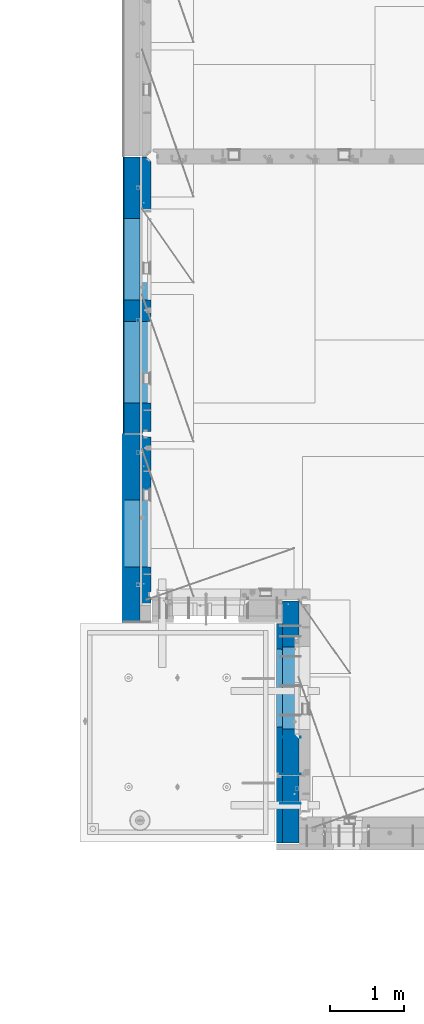
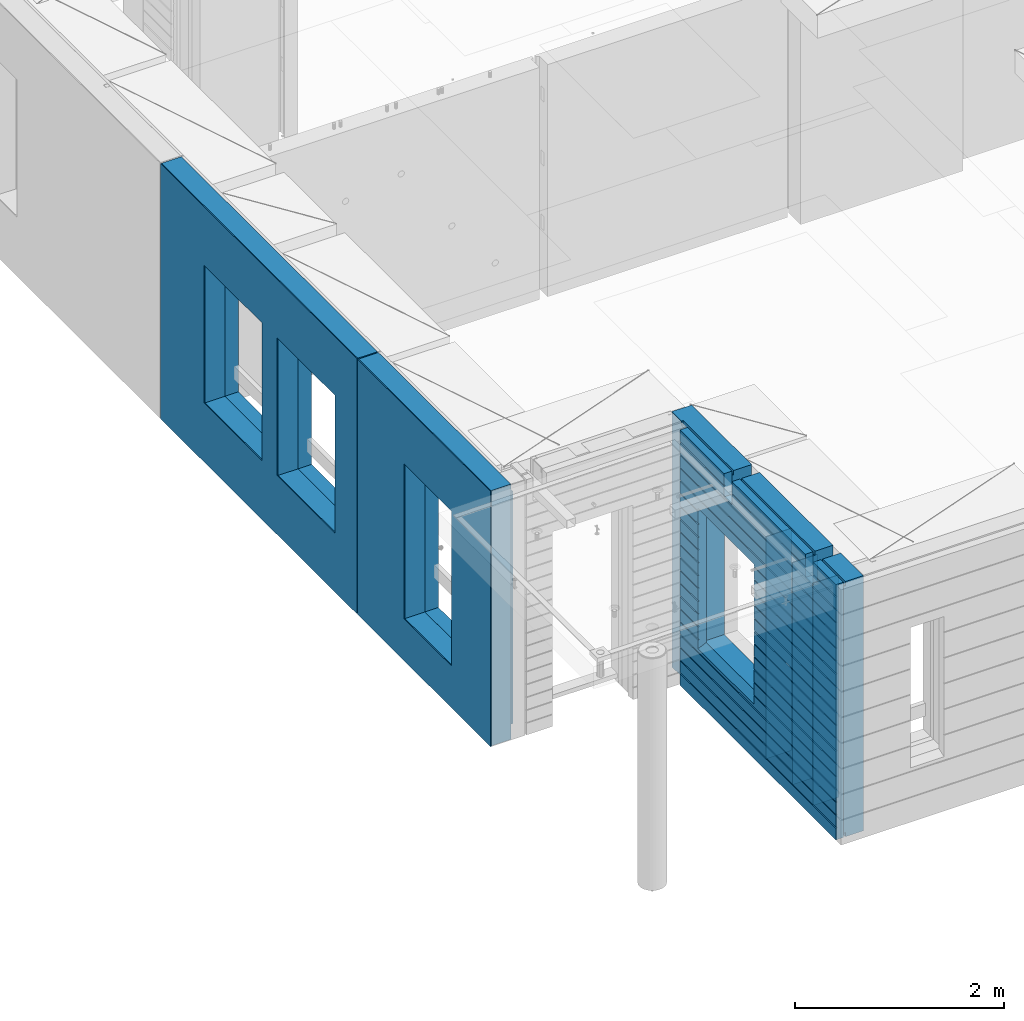
# One storey, part 228 of 352: 11 walls, 3 elements without a shape of their own.
"""IFC2X3 building model written with IfcOpenShell, lengths in millimetres."""

from ifc_helpers import new_model, si_unit, frame, origin_with_axes, place, context, subcontext, project, spatial, faceted_brep, material, type_object, element, aggregate, save


model = new_model("IFC2X3")

# Units and contexts
model_context = context("Model", 3, precision=1e-05, world=origin_with_axes())
body_context = subcontext(model_context, "Body", "Model", "MODEL_VIEW")
ifc_project = project(units=[si_unit("LENGTHUNIT", "METRE", prefix="MILLI"), si_unit("AREAUNIT", "SQUARE_METRE"), si_unit("VOLUMEUNIT", "CUBIC_METRE"), si_unit("MASSUNIT", "GRAM", prefix="KILO"), si_unit("TIMEUNIT", "SECOND"), si_unit("PLANEANGLEUNIT", "RADIAN"), si_unit("SOLIDANGLEUNIT", "STERADIAN"), si_unit("THERMODYNAMICTEMPERATUREUNIT", "DEGREE_CELSIUS"), si_unit("LUMINOUSINTENSITYUNIT", "LUMEN")], contexts=[model_context])

# Site, building, storey
site_placement = place(None, origin_with_axes())
site = spatial("IfcSite", under=ifc_project, at=site_placement, CompositionType="ELEMENT")
building_placement = place(site_placement, origin_with_axes())
building = spatial("IfcBuilding", under=site, at=building_placement, CompositionType="ELEMENT")
storey_placement = place(building_placement, origin_with_axes())
storey = spatial("IfcBuildingStorey", under=building, at=storey_placement, Name="6", CompositionType="ELEMENT", Elevation=0.0)

# Assembly, walls
assembly_1_placement = place(storey_placement, origin_with_axes())
assembly_1 = element("IfcElementAssembly", 1, at=assembly_1_placement, inside=storey, AssemblyPlace="NOTDEFINED", PredefinedType="REINFORCEMENT_UNIT")
ifc_material_1 = material(Name="Undefined")
wall_type_1 = type_object("IfcWallType", PredefinedType="NOTDEFINED")
wall_1_placement = place(assembly_1_placement, frame((10040.0, 8580.0, 98115.0), z_axis=(0.0, 0.0, 1.0), x_axis=(-1.0, 3.00000001838171e-08, 0.0)))
wall_1 = element("IfcWall", 2, at=wall_1_placement, type_object=wall_type_1, material=ifc_material_1, Name="(PD)", context=body_context, shape_type="Brep", body=[
    faceted_brep([(0.0, 5.0, -1300.0), (0.0, 5.0, 1300.0), (280.0, 5.0, 1300.0), (280.0, 5.0, -1300.0), (0.0, -5.0, 1300.0), (280.0, -5.0, 1300.0), (0.0, -5.0, -1300.0), (280.0, -5.0, -1300.0)], [[[0, 1, 2, 3]], [[1, 4, 5, 2]], [[4, 6, 7, 5]], [[6, 0, 3, 7]], [[5, 7, 3, 2]], [[6, 4, 1, 0]]]),
])
wall_2_placement = place(assembly_1_placement, frame((10040.0, 8180.0, 98115.0), z_axis=(0.0, 0.0, 1.0), x_axis=(-1.0, 3.00000001838171e-08, 0.0)))
wall_2 = element("IfcWall", 3, at=wall_2_placement, type_object=wall_type_1, material=ifc_material_1, Name="(PD)", context=body_context, shape_type="Brep", body=[
    faceted_brep([(0.0, 5.0, -1300.0), (0.0, 5.0, 1300.0), (280.0, 5.0, 1300.0), (280.0, 5.0, -1300.0), (0.0, -5.0, 1300.0), (280.0, -5.0, 1300.0), (0.0, -5.0, -1300.0), (280.0, -5.0, -1300.0)], [[[0, 1, 2, 3]], [[1, 4, 5, 2]], [[4, 6, 7, 5]], [[6, 0, 3, 7]], [[5, 7, 3, 2]], [[6, 4, 1, 0]]]),
])
wall_3_placement = place(assembly_1_placement, frame((10040.0, 9080.0, 98115.0), z_axis=(0.0, 0.0, 1.0), x_axis=(-1.0, 3.00000001838171e-08, 0.0)))
wall_3 = element("IfcWall", 4, at=wall_3_placement, type_object=wall_type_1, material=ifc_material_1, Name="(PD)", context=body_context, shape_type="Brep", body=[
    faceted_brep([(0.0, 5.0, -1300.0), (0.0, 5.0, 1300.0), (280.0, 5.0, 1300.0), (280.0, 5.0, -1300.0), (0.0, -5.0, 1300.0), (280.0, -5.0, 1300.0), (0.0, -5.0, -1300.0), (280.0, -5.0, -1300.0)], [[[0, 1, 2, 3]], [[1, 4, 5, 2]], [[4, 6, 7, 5]], [[6, 0, 3, 7]], [[5, 7, 3, 2]], [[6, 4, 1, 0]]]),
])
ifc_material_2 = material(Name="COS5gt")
wall_type_2 = type_object("IfcWallType", PredefinedType="NOTDEFINED")
wall_4_placement = place(assembly_1_placement, frame((9900.0, 8000.0, 98247.5), z_axis=(0.0, 0.0, 1.0), x_axis=(0.0, 1.0, 0.0)))
wall_4 = element("IfcWall", 5, at=wall_4_placement, type_object=wall_type_2, material=ifc_material_2, context=body_context, shape_type="Brep", body=[
    faceted_brep([(-355.0, 110.0, -1442.5), (2751.0, 110.0, -1442.5), (2751.0, 90.0, -1442.5), (-355.0, 90.0, -1442.5), (2935.0, 110.0, -1492.5), (2935.0, -110.0, -1492.5), (-355.0, -110.0, -1492.5), (-355.0, 90.0, -1492.5), (2751.0, 90.0, -1492.5), (2751.0, 110.0, -1492.5), (2935.0, -110.0, 1492.5), (2935.0, 110.0, 1492.5), (2751.0, 110.0, 1492.5), (2751.0, 90.0, 1492.5), (1785.0, 90.0, 1492.5), (1785.0, -110.0, 1492.5), (2751.0, 90.0, 1442.5), (1785.0, 90.0, 1442.5), (2751.0, 110.0, 1442.5), (1785.0, 110.0, 1442.5), (1785.0, 110.0, 1222.5), (1785.0, -110.0, 1222.5), (1635.0, 110.0, 1222.5), (1635.0, -110.0, 1222.5), (1635.0, -110.0, 1492.5), (1635.0, 90.0, 1492.5), (229.999999999998, 90.0, 1492.5), (229.999999999998, -110.0, 1492.5), (1635.0, 90.0, 1442.5), (229.999999999998, 90.0, 1442.5), (1635.0, 110.0, 1442.5), (229.999999999998, 110.0, 1442.5), (-355.0, 110.0, 1442.5), (-355.0, 90.0, 1442.5), (79.9999999999982, 90.0, 1442.5), (79.9999999999982, 110.0, 1442.5), (-355.0, 90.0, 1492.5), (-355.0, -110.0, 1492.5), (79.9999999999982, -110.0, 1492.5), (79.9999999999982, 90.0, 1492.5), (79.9999999999982, -110.0, 1222.5), (79.9999999999982, 110.0, 1222.5), (229.999999999998, -110.0, 1222.5), (229.999999999998, 110.0, 1222.5), (1189.05717134203, -110.0, -813.445945945859), (1189.05717134203, -110.0, 813.445945945859), (2310.94906323375, -110.0, 813.445945945859), (2310.94906323375, -110.0, -813.445945945859), (1195.00311728789, 109.999999996904, -807.5), (1195.00311728789, 109.999999996904, -802.5), (1195.00311728789, 109.999999996904, 807.5), (2305.00311728789, 109.999999996904, -807.5), (2275.00311728789, 109.999999996904, -807.5), (1225.00311728789, 109.999999996904, -807.5), (2305.00311728789, 109.999999996904, 807.5), (2305.00311728789, 109.999999996904, -802.5)], [[[0, 1, 2, 3]], [[4, 5, 6, 7, 8, 9]], [[10, 5, 4, 11]], [[10, 11, 12, 13, 14, 15]], [[13, 16, 17, 14]], [[12, 18, 16, 13]], [[16, 18, 19, 17]], [[15, 14, 17, 19, 20, 21]], [[21, 20, 22, 23]], [[24, 25, 26, 27]], [[25, 28, 29, 26]], [[24, 23, 22, 30, 28, 25]], [[28, 30, 31, 29]], [[32, 33, 34, 35]], [[36, 37, 38, 39]], [[33, 36, 39, 34]], [[38, 40, 41, 35, 34, 39]], [[42, 43, 41, 40]], [[27, 26, 29, 31, 43, 42]], [[40, 38, 37, 6, 5, 10, 15, 21, 23, 24, 27, 42], [44, 45, 46, 47]], [[44, 48, 49, 50, 45]], [[47, 51, 52, 53, 48, 44]], [[46, 54, 55, 51, 47]], [[45, 50, 54, 46]], [[30, 22, 20, 19, 18, 12, 11, 4, 9, 1, 0, 32, 35, 41, 43, 31], [49, 48, 53, 52, 51, 55, 54, 50]], [[8, 2, 1, 9]], [[7, 3, 2, 8]], [[6, 37, 36, 33, 32, 0, 3, 7]]]),
])

# Assembly, wall
assembly_2_placement = place(storey_placement, origin_with_axes())
assembly_2 = element("IfcElementAssembly", 6, at=assembly_2_placement, inside=storey, AssemblyPlace="NOTDEFINED", PredefinedType="REINFORCEMENT_UNIT")
ifc_material_3 = material()
wall_5_placement = place(assembly_2_placement, frame((7739.99972588711, 13210.0004309454, 98247.5), z_axis=(0.0, 0.0, 1.0), x_axis=(0.0, 1.0, 0.0)))
wall_5 = element("IfcWall", 7, at=wall_5_placement, type_object=wall_type_2, material=ifc_material_3, context=body_context, shape_type="Brep", body=[
    faceted_brep([(0.0, 110.0, 1492.5), (0.0, -110.0, 1492.5), (3759.99957708461, -110.0, 1492.5), (3759.99956102462, 110.0, 1492.5), (0.0, -110.0, -1492.5), (0.0, 110.0, -1492.5), (3759.99956102462, 110.0, -1492.5), (3759.99957708461, -110.0, -1492.5), (414.999554466332, -110.0, -802.5), (414.999554466332, -110.0, 807.5), (1524.99955446633, -110.000000000001, 807.5), (1524.99955446633, -110.000000000001, -802.5), (1814.99999876569, -110.0, -802.5), (1814.99999876569, -110.0, 807.5), (2924.99999876569, -110.0, 807.5), (2924.99999876569, -110.0, -802.5), (1814.99999876569, 110.0, -802.5), (1814.99999876569, 110.0, 807.5), (2924.99999876569, 110.0, -802.5), (2924.99999876569, 110.0, 807.5), (414.999554466332, 110.0, -802.5), (1524.99955446633, 109.999999999999, -802.5), (1524.99955446633, 109.999999999999, 807.5), (414.999554466332, 110.0, 807.5)], [[[0, 1, 2, 3]], [[4, 1, 0, 5]], [[4, 5, 6, 7]], [[2, 7, 6, 3]], [[1, 4, 7, 2], [8, 9, 10, 11], [12, 13, 14, 15]], [[12, 16, 17, 13]], [[15, 18, 16, 12]], [[14, 19, 18, 15]], [[13, 17, 19, 14]], [[5, 0, 3, 6], [20, 21, 22, 23], [16, 18, 19, 17]], [[10, 22, 21, 11]], [[9, 23, 22, 10]], [[8, 20, 23, 9]], [[11, 21, 20, 8]]]),
])

assembly_3_placement = place(storey_placement, origin_with_axes())
assembly_3 = element("IfcElementAssembly", 8, at=assembly_3_placement, inside=storey, AssemblyPlace="NOTDEFINED", PredefinedType="REINFORCEMENT_UNIT")
wall_6_placement = place(assembly_3_placement, frame((7740.00002947772, 10874.9996836349, 98247.5), z_axis=(0.0, 0.0, 1.0), x_axis=(0.0, 1.0, 0.0)))
wall_6 = element("IfcWall", 9, at=wall_6_placement, type_object=wall_type_2, material=ifc_material_3, context=body_context, shape_type="Brep", body=[
    faceted_brep([(-219.99966922487, -110.0, 1492.5), (-219.99966922487, -110.0, -1492.5), (2320.00069431996, -110.000000000001, -1492.5), (2320.00069431996, -110.000000000001, 1492.5), (520.000578694053, -110.000000000001, -1002.5), (520.000578694053, -110.000000000001, 807.5), (1430.00057869405, -110.000000000001, 807.5), (1430.00057869405, -110.000000000001, -1002.5), (-219.99966922487, 110.0, 1492.5), (2320.00069431997, 110.0, 1492.5), (-219.99966922487, 110.0, -1492.5), (2320.00069431997, 110.0, -1492.5), (520.000578694055, 110.0, -1002.5), (1430.00057869406, 110.0, -1002.5), (1430.00057869406, 110.0, 807.5), (520.000578694055, 110.0, 807.5)], [[[0, 1, 2, 3], [4, 5, 6, 7]], [[8, 0, 3, 9]], [[1, 0, 8, 10]], [[1, 10, 11, 2]], [[3, 2, 11, 9]], [[10, 8, 9, 11], [12, 13, 14, 15]], [[6, 14, 13, 7]], [[5, 15, 14, 6]], [[4, 12, 15, 5]], [[7, 13, 12, 4]]]),
])

# Wall
ifc_material_4 = material(Name="CONCRETE/C30/37")
wall_type_3 = type_object("IfcWallType", PredefinedType="NOTDEFINED")
wall_7_placement = place(assembly_1_placement, frame((9747.5, 8000.0, 98247.5), z_axis=(0.0, 0.0, 1.0), x_axis=(0.0, 1.0, 0.0)))
wall_7 = element("IfcWall", 10, at=wall_7_placement, type_object=wall_type_3, material=ifc_material_4, context=body_context, shape_type="Brep", body=[
    faceted_brep([(-355.0, 32.4999992499324, 1344.99999999921), (-355.0, 32.4999991119385, 1355.00000040044), (79.9999999999982, 32.4999991119385, 1355.00000040044), (79.9999999999982, 32.4999992499324, 1344.99999999921), (-355.0, 42.5, 1342.99999994476), (79.9999999999982, 42.5, 1342.99999994476), (2630.0, 32.4999991119385, 1355.00000040044), (2630.0, 32.4999992499324, 1344.99999999921), (1785.0, 32.4999992499324, 1344.99999999921), (1785.0, 32.4999991119385, 1355.00000040044), (2630.0, 42.5, 1356.99999988925), (1785.0, 42.5, 1356.99999988925), (2630.0, 42.5, 1492.5), (1785.0, 42.5, 1492.5), (2630.0, -42.5, 1492.5), (1785.0, -42.5, 1492.5), (-355.0, -42.5, -1492.5), (-355.0, 42.5, -1492.5), (2630.0, 42.5, -1492.5), (2630.0, -42.5, -1492.5), (-355.0, 42.5, -1357.00000005524), (2630.0, 42.5, -1357.00000005524), (-355.0, 32.4999992506928, -1355.0000000008), (2630.0, 32.4999992506928, -1355.0000000008), (-355.0, 32.4999991126915, -1344.99999959957), (2630.0, 32.4999991126915, -1344.99999959957), (-355.0, 42.5, -1343.00000011075), (2630.0, 42.5, -1343.00000011075), (-355.0, 42.5, -1207.00000005524), (2630.0, 42.5, -1207.00000005524), (-355.0, 32.4999992506928, -1205.0000000008), (2630.0, 32.4999992506928, -1205.0000000008), (-355.0, 32.4999991126915, -1194.99999959957), (2630.0, 32.4999991126915, -1194.99999959957), (-355.0, 42.5, -1193.00000011075), (2630.0, 42.5, -1193.00000011075), (-355.0, 42.5, -1057.00000005525), (2630.0, 42.5, -1057.00000005525), (-355.0, 32.4999992512294, -1055.00000000081), (2630.0, 32.4999992512294, -1055.00000000081), (-355.0, 32.4999991132281, -1044.99999959959), (2630.0, 32.4999991132281, -1044.99999959959), (-355.0, 42.5, -1043.00000011077), (2630.0, 42.5, -1043.00000011077), (-355.0, 42.5, -907.000000055225), (2630.0, 42.5, -907.000000055225), (-355.000000000001, 32.4999992517678, -905.000000000786), (2630.0, 32.4999992517678, -905.000000000786), (-355.000000000001, 32.4999991137665, -894.99999959956), (2630.0, 32.4999991137665, -894.99999959956), (-355.0, 42.5, -893.00000011074), (2630.0, 42.5, -893.00000011074), (2630.0, 42.5, -307.000000055239), (2630.0, 32.4999992538942, -305.0000000008), (2630.0, 32.4999991158911, -294.999999599575), (2630.0, 42.5, -293.000000110755), (2630.0, 42.5, -157.000000055254), (2630.0, 32.4999992544235, -155.000000000815), (2630.0, 32.4999991164223, -144.99999959959), (2630.0, 42.5, -143.000000110769), (2630.0, 42.5, -7.00000005523907), (2630.0, 32.4999992500489, -5.0000000007858), (2630.0, 32.4999991120549, 5.0000004004396), (2630.0, 42.5, 6.99999988924537), (2630.0, 42.5, 142.999999944761), (2630.0, 32.4999992500361, 144.999999999214), (2630.0, 32.4999991120421, 155.00000040044), (2630.0, 42.5, 156.999999889245), (2630.0, 42.5, 292.999999944761), (2630.0, 32.4999992500234, 294.999999999214), (2630.0, 32.4999991120294, 305.00000040044), (2630.0, 42.5, 306.999999889245), (2630.0, 42.5, 442.999999944761), (2630.0, 32.4999992500107, 444.999999999214), (2630.0, 32.4999991120167, 455.00000040044), (2630.0, 42.5, 456.999999889245), (2630.0, 42.5, 592.999999944761), (2630.0, 32.4999992499979, 594.999999999214), (2630.0, 32.4999991120039, 605.00000040044), (2630.0, 42.5, 606.999999889245), (2630.0, 42.5, 742.999999944761), (2630.0, 32.4999992499852, 744.999999999214), (2630.0, 32.4999991119912, 755.00000040044), (2630.0, 42.5, 756.999999889245), (2630.0, 42.5, 892.999999944761), (2630.0, 32.4999992499725, 894.999999999214), (2630.0, 32.4999991119785, 905.00000040044), (2630.0, 42.5, 906.999999889245), (2630.0, 42.5, 1042.99999994476), (2630.0, 32.4999992499597, 1044.99999999921), (2630.0, 32.4999991119657, 1055.00000040044), (2630.0, 42.5, 1056.99999988925), (2630.0, 42.5, 1192.99999994476), (2630.0, 32.499999249947, 1194.99999999921), (2630.0, 32.499999111953, 1205.00000040044), (2630.0, 42.5, 1206.99999988925), (2630.0, 42.5, 1342.99999994476), (2630.0, 42.5, -757.000000055225), (2630.0, 32.4999992522953, -755.000000000786), (2630.0, 32.499999114294, -744.99999959956), (2630.0, 42.5, -743.00000011074), (2630.0, 42.5, -607.000000055225), (2630.0, 32.4999992522953, -605.000000000786), (2630.0, 32.499999114294, -594.99999959956), (2630.0, 42.5, -593.00000011074), (2630.0, 42.5, -457.000000055225), (2630.0, 32.4999992522953, -455.000000000786), (2630.0, 32.499999114294, -444.99999959956), (2630.0, 42.5, -443.00000011074), (1785.0, 42.5, 1342.99999994476), (1785.0, 42.5, 1222.5), (1785.0, -42.5, 1222.5), (1635.0, 42.5, 1222.5), (1635.0, -42.5, 1222.5), (1635.0, -42.5, 1492.5), (1635.0, 42.5, 1492.5), (229.999999999998, 42.5, 1492.5), (229.999999999998, -42.5, 1492.5), (1635.0, 32.4999991119385, 1355.00000040044), (1635.0, 32.4999992499324, 1344.99999999921), (229.999999999998, 32.4999992499324, 1344.99999999921), (229.999999999998, 32.4999991119385, 1355.00000040044), (1635.0, 42.5, 1356.99999988925), (229.999999999998, 42.5, 1356.99999988925), (1635.0, 42.5, 1342.99999994476), (229.999999999998, 42.5, 1342.99999994476), (229.999999999998, -42.5, 1222.5), (229.999999999998, 42.5, 1222.5), (79.9999999999982, 42.5, 1222.5), (79.9999999999982, -42.5, 1222.5), (-355.0, 42.5, 1206.99999988925), (-355.0, 32.499999111953, 1205.00000040044), (-355.0, 32.499999249947, 1194.99999999921), (-355.0, 42.5, 1192.99999994476), (-355.0, 42.5, 1056.99999988925), (-355.0, 32.4999991119657, 1055.00000040044), (-355.0, 32.4999992499597, 1044.99999999921), (-355.0, 42.5, 1042.99999994476), (-355.0, 42.5, 906.999999889245), (-354.999999999999, 32.4999991119785, 905.00000040044), (-354.999999999999, 32.4999992499725, 894.999999999214), (-355.0, 42.5, 892.999999944761), (-355.0, 42.5, -457.000000055225), (-355.0, 42.5, -593.00000011074), (-354.999999999998, 32.499999114294, -594.99999959956), (-354.999999999998, 32.4999992522953, -605.000000000786), (-355.0, 42.5, -607.000000055225), (-355.0, 42.5, -743.00000011074), (-355.0, 32.499999114294, -744.99999959956), (-355.0, 32.4999992522953, -755.000000000786), (-355.0, 42.5, -757.000000055225), (-355.0, -42.5, 1492.5), (-355.0, 42.5, 1492.5), (-355.0, 42.5, 1356.99999988925), (-355.0, 42.5, 756.999999889245), (-354.999999999999, 32.4999991119912, 755.00000040044), (-354.999999999999, 32.4999992499852, 744.999999999214), (-355.0, 42.5, 742.999999944761), (-355.0, 42.5, 606.999999889245), (-355.0, 32.4999991120039, 605.00000040044), (-355.0, 32.4999992499979, 594.999999999214), (-355.0, 42.5, 592.999999944761), (-355.0, 42.5, 456.999999889245), (-355.0, 32.4999991120167, 455.00000040044), (-355.0, 32.4999992500107, 444.999999999214), (-355.0, 42.5, 442.999999944761), (-355.0, 42.5, 306.999999889245), (-355.0, 32.4999991120294, 305.00000040044), (-355.0, 32.4999992500234, 294.999999999214), (-355.0, 42.5, 292.999999944761), (-355.0, 42.5, 156.999999889245), (-355.0, 32.4999991120421, 155.00000040044), (-355.0, 32.4999992500361, 144.999999999214), (-355.0, 42.5, 142.999999944761), (-355.0, 42.5, 6.99999988924537), (-355.0, 32.4999991120549, 5.0000004004396), (-355.0, 32.4999992500489, -5.0000000007858), (-355.0, 42.5, -7.00000005523907), (-355.0, 42.5, -143.000000110769), (-354.999999999999, 32.4999991164223, -144.99999959959), (-354.999999999999, 32.4999992544235, -155.000000000815), (-355.0, 42.5, -157.000000055254), (-355.0, 42.5, -293.000000110755), (-355.0, 32.4999991158911, -294.999999599575), (-355.0, 32.4999992538942, -305.0000000008), (-355.0, 42.5, -307.000000055239), (-355.0, 42.5, -443.00000011074), (-355.000000000001, 32.499999114294, -444.99999959956), (-355.000000000001, 32.4999992522953, -455.000000000786), (1215.00311728789, 42.5, 756.999999889245), (1216.1795879806, 32.4999991119912, 755.00000040044), (1216.17958796436, 32.4999992499852, 744.999999999214), (1215.00311728789, 42.5, 742.999999944761), (1215.00311728789, 42.5, 606.999999889245), (1216.1795879806, 32.4999991120039, 605.00000040044), (1216.17958796436, 32.4999992499979, 594.999999999214), (1215.00311728789, 42.5, 592.999999944761), (1215.00311728789, 42.5, 456.999999889245), (1216.17958798059, 32.4999991120167, 455.00000040044), (1216.17958796436, 32.4999992500107, 444.999999999214), (1215.00311728789, 42.5, 442.999999944761), (1215.00311728789, 42.5, 306.999999889245), (1216.17958798059, 32.4999991120294, 305.00000040044), (1216.17958796436, 32.4999992500234, 294.999999999214), (1215.00311728789, 42.5, 292.999999944761), (1215.00311728789, 42.5, 156.999999889245), (1216.17958798059, 32.4999991120421, 155.00000040044), (1216.17958796436, 32.4999992500361, 144.999999999214), (1215.00311728789, 42.5, 142.999999944761), (1215.00311728789, 42.5, 6.99999988924537), (1216.17958798059, 32.4999991120549, 5.0000004004396), (1216.17958796435, 32.4999992500489, -5.0000000007858), (1215.00311728789, 42.5, -7.00000005523907), (1215.00311728789, 42.5, -143.000000110769), (1216.17958798008, 32.4999991164223, -144.99999959959), (1216.17958796384, 32.4999992544235, -155.000000000815), (1215.00311728789, 42.5, -157.000000055254), (1215.00311728789, 42.5, -293.000000110755), (1216.17958798014, 32.4999991158911, -294.999999599575), (1216.1795879639, 32.4999992538942, -305.0000000008), (1215.00311728789, 42.5, -307.000000055239), (1215.00311728789, 42.5, -443.00000011074), (1216.17958798033, 32.499999114294, -444.99999959956), (1216.17958796409, 32.4999992522953, -455.000000000786), (1215.00311728789, 42.5, -457.000000055225), (1215.00311728789, 42.5, -593.00000011074), (1216.17958798033, 32.499999114294, -594.99999959956), (1216.17958796409, 32.4999992522953, -605.000000000786), (1215.00311728789, 42.5, -607.000000055225), (1215.00311728789, 42.5, -743.00000011074), (1216.17958798033, 32.499999114294, -744.99999959956), (1216.17958796409, 32.4999992522953, -755.000000000786), (1215.00311728789, 42.5, -757.000000055225), (1215.00311728789, 42.5, -857.5), (2285.00311728789, 42.5, -857.5), (2285.00311728789, 42.5, -757.000000055225), (2283.82664661169, 32.4999992522953, -755.000000000786), (2283.82664659545, 32.499999114294, -744.99999959956), (2285.00311728789, 42.5, -743.00000011074), (2285.00311728789, 42.5, -607.000000055225), (2283.82664661169, 32.4999992522953, -605.000000000786), (2283.82664659545, 32.499999114294, -594.99999959956), (2285.00311728789, 42.5, -593.00000011074), (2285.00311728789, 42.5, -457.000000055225), (2283.82664661169, 32.4999992522953, -455.000000000786), (2283.82664659545, 32.499999114294, -444.99999959956), (2285.00311728789, 42.5, -443.00000011074), (2285.00311728789, 42.5, -307.000000055239), (2283.82664661188, 32.4999992538942, -305.0000000008), (2283.82664659564, 32.4999991158911, -294.999999599575), (2285.00311728789, 42.5, -293.000000110755), (2285.00311728789, 42.5, -157.000000055254), (2283.82664661194, 32.4999992544235, -155.000000000815), (2283.82664659571, 32.4999991164223, -144.99999959959), (2285.00311728789, 42.5, -143.000000110769), (2285.00311728789, 42.5, -7.00000005523907), (2283.82664661143, 32.4999992500489, -5.0000000007858), (2283.82664659519, 32.4999991120549, 5.0000004004396), (2285.00311728789, 42.5, 6.99999988924537), (2285.00311728789, 42.5, 142.999999944761), (2283.82664661143, 32.4999992500361, 144.999999999214), (2283.82664659519, 32.4999991120421, 155.00000040044), (2285.00311728789, 42.5, 156.999999889245), (2285.00311728789, 42.5, 292.999999944761), (2283.82664661142, 32.4999992500234, 294.999999999214), (2283.82664659519, 32.4999991120294, 305.00000040044), (2285.00311728789, 42.5, 306.999999889245), (2285.00311728789, 42.5, 442.999999944761), (2283.82664661142, 32.4999992500107, 444.999999999214), (2283.82664659519, 32.4999991120167, 455.00000040044), (2285.00311728789, 42.5, 456.999999889245), (2285.00311728789, 42.5, 592.999999944761), (2283.82664661142, 32.4999992499979, 594.999999999214), (2283.82664659519, 32.4999991120039, 605.00000040044), (2285.00311728789, 42.5, 606.999999889245), (2285.00311728789, 42.5, 742.999999944761), (2283.82664661142, 32.4999992499852, 744.999999999214), (2283.82664659518, 32.4999991119912, 755.00000040044), (2285.00311728789, 42.5, 756.999999889245), (1225.00311728789, 42.5, 782.5), (1215.00311728789, 42.5, 782.5), (2285.00311728789, 42.5, 782.5), (2275.00311728789, 42.5, 782.5), (1225.00311728789, -42.5, 787.5), (2275.00311728789, -42.5, 787.5), (1225.00311728789, -42.5, 782.5), (1225.00311728789, -42.5, -807.5), (2275.00311728789, -42.5, -807.5), (2275.00311728789, -42.5, 782.5), (79.9999999999982, -42.5, 1492.5), (79.9999999999982, 42.5, 1492.5), (79.9999999999982, 42.5, 1356.99999988925)], [[[0, 1, 2, 3]], [[4, 0, 3, 5]], [[6, 7, 8, 9]], [[10, 6, 9, 11]], [[12, 10, 11, 13]], [[14, 12, 13, 15]], [[16, 17, 18, 19]], [[18, 17, 20, 21]], [[21, 20, 22, 23]], [[23, 22, 24, 25]], [[25, 24, 26, 27]], [[28, 29, 27, 26]], [[29, 28, 30, 31]], [[31, 30, 32, 33]], [[33, 32, 34, 35]], [[35, 34, 36, 37]], [[37, 36, 38, 39]], [[39, 38, 40, 41]], [[41, 40, 42, 43]], [[43, 42, 44, 45]], [[45, 44, 46, 47]], [[47, 46, 48, 49]], [[49, 48, 50, 51]], [[52, 53, 54, 55, 56, 57, 58, 59, 60, 61, 62, 63, 64, 65, 66, 67, 68, 69, 70, 71, 72, 73, 74, 75, 76, 77, 78, 79, 80, 81, 82, 83, 84, 85, 86, 87, 88, 89, 90, 91, 92, 93, 94, 95, 96, 7, 6, 10, 12, 14, 19, 18, 21, 23, 25, 27, 29, 31, 33, 35, 37, 39, 41, 43, 45, 47, 49, 51, 97, 98, 99, 100, 101, 102, 103, 104, 105, 106, 107, 108]], [[7, 96, 109, 8]], [[15, 13, 11, 9, 8, 109, 110, 111]], [[111, 110, 112, 113]], [[114, 115, 116, 117]], [[118, 119, 120, 121]], [[122, 118, 121, 123]], [[115, 122, 123, 116]], [[114, 113, 112, 124, 119, 118, 122, 115]], [[119, 124, 125, 120]], [[126, 127, 128, 129]], [[117, 116, 123, 121, 120, 125, 127, 126]], [[124, 112, 110, 109, 96, 95, 130, 4, 5, 128, 127, 125]], [[94, 131, 130, 95]], [[93, 132, 131, 94]], [[92, 133, 132, 93]], [[91, 134, 133, 92]], [[90, 135, 134, 91]], [[89, 136, 135, 90]], [[88, 137, 136, 89]], [[87, 138, 137, 88]], [[86, 139, 138, 87]], [[85, 140, 139, 86]], [[84, 141, 140, 85]], [[142, 143, 144, 145, 146, 147, 148, 149, 150, 50, 48, 46, 44, 42, 40, 38, 36, 34, 32, 30, 28, 26, 24, 22, 20, 17, 16, 151, 152, 153, 1, 0, 4, 130, 131, 132, 133, 134, 135, 136, 137, 138, 139, 140, 141, 154, 155, 156, 157, 158, 159, 160, 161, 162, 163, 164, 165, 166, 167, 168, 169, 170, 171, 172, 173, 174, 175, 176, 177, 178, 179, 180, 181, 182, 183, 184, 185, 186, 187, 188]], [[155, 154, 189, 190]], [[156, 155, 190, 191]], [[157, 156, 191, 192]], [[158, 157, 192, 193]], [[159, 158, 193, 194]], [[160, 159, 194, 195]], [[161, 160, 195, 196]], [[162, 161, 196, 197]], [[163, 162, 197, 198]], [[164, 163, 198, 199]], [[165, 164, 199, 200]], [[166, 165, 200, 201]], [[167, 166, 201, 202]], [[168, 167, 202, 203]], [[169, 168, 203, 204]], [[170, 169, 204, 205]], [[171, 170, 205, 206]], [[172, 171, 206, 207]], [[173, 172, 207, 208]], [[174, 173, 208, 209]], [[175, 174, 209, 210]], [[176, 175, 210, 211]], [[177, 176, 211, 212]], [[178, 177, 212, 213]], [[179, 178, 213, 214]], [[180, 179, 214, 215]], [[181, 180, 215, 216]], [[182, 181, 216, 217]], [[183, 182, 217, 218]], [[184, 183, 218, 219]], [[185, 184, 219, 220]], [[186, 185, 220, 221]], [[187, 186, 221, 222]], [[188, 187, 222, 223]], [[142, 188, 223, 224]], [[143, 142, 224, 225]], [[144, 143, 225, 226]], [[145, 144, 226, 227]], [[146, 145, 227, 228]], [[147, 146, 228, 229]], [[148, 147, 229, 230]], [[149, 148, 230, 231]], [[150, 149, 231, 232]], [[97, 51, 50, 150, 232, 233, 234, 235]], [[98, 97, 235, 236]], [[99, 98, 236, 237]], [[100, 99, 237, 238]], [[101, 100, 238, 239]], [[102, 101, 239, 240]], [[103, 102, 240, 241]], [[104, 103, 241, 242]], [[105, 104, 242, 243]], [[106, 105, 243, 244]], [[107, 106, 244, 245]], [[108, 107, 245, 246]], [[52, 108, 246, 247]], [[53, 52, 247, 248]], [[54, 53, 248, 249]], [[55, 54, 249, 250]], [[56, 55, 250, 251]], [[57, 56, 251, 252]], [[58, 57, 252, 253]], [[59, 58, 253, 254]], [[60, 59, 254, 255]], [[61, 60, 255, 256]], [[62, 61, 256, 257]], [[63, 62, 257, 258]], [[64, 63, 258, 259]], [[65, 64, 259, 260]], [[66, 65, 260, 261]], [[67, 66, 261, 262]], [[68, 67, 262, 263]], [[69, 68, 263, 264]], [[70, 69, 264, 265]], [[71, 70, 265, 266]], [[72, 71, 266, 267]], [[73, 72, 267, 268]], [[74, 73, 268, 269]], [[75, 74, 269, 270]], [[76, 75, 270, 271]], [[77, 76, 271, 272]], [[78, 77, 272, 273]], [[79, 78, 273, 274]], [[80, 79, 274, 275]], [[81, 80, 275, 276]], [[82, 81, 276, 277]], [[83, 82, 277, 278]], [[279, 280, 189, 154, 141, 84, 83, 278, 281, 282]], [[283, 280, 279, 282, 281, 284]], [[285, 286, 233, 232, 231, 230, 229, 228, 227, 226, 225, 224, 223, 222, 221, 220, 219, 218, 217, 216, 215, 214, 213, 212, 211, 210, 209, 208, 207, 206, 205, 204, 203, 202, 201, 200, 199, 198, 197, 196, 195, 194, 193, 192, 191, 190, 189, 280, 283]], [[287, 234, 233, 286]], [[288, 284, 281, 278, 277, 276, 275, 274, 273, 272, 271, 270, 269, 268, 267, 266, 265, 264, 263, 262, 261, 260, 259, 258, 257, 256, 255, 254, 253, 252, 251, 250, 249, 248, 247, 246, 245, 244, 243, 242, 241, 240, 239, 238, 237, 236, 235, 234, 287]], [[129, 289, 151, 16, 19, 14, 15, 111, 113, 114, 117, 126], [287, 286, 285, 283, 284, 288]], [[152, 151, 289, 290]], [[153, 152, 290, 291]], [[289, 129, 128, 5, 3, 2, 291, 290]], [[1, 153, 291, 2]]]),
])

aggregate(assembly_1, [wall_1, wall_2, wall_3, wall_4, wall_7])

ifc_material_5 = material(Name="CONCRETE/C25/30")
wall_type_4 = type_object("IfcWallType", PredefinedType="NOTDEFINED")
wall_8_placement = place(assembly_2_placement, frame((7924.9997258893, 13210.0004174404, 98112.5), z_axis=(0.0, 0.0, 1.0), x_axis=(0.0, 1.0, 0.0)))
wall_8 = element("IfcWall", 11, at=wall_8_placement, type_object=wall_type_4, material=ifc_material_5, context=body_context, shape_type="Brep", body=[
    faceted_brep([(1524.99955451006, -75.0000000617138, -667.5), (1524.99955451006, 75.0, -667.5), (414.999554510065, 75.0, -667.5), (414.999554510063, -75.000000114278, -667.5), (414.999554510065, 75.0, 942.5), (414.999554510063, -75.0000002207053, 942.5), (1524.99955451006, 75.0, 942.5), (1524.99955451006, -75.000000168141, 942.5), (0.0, 45.0, 1357.5), (0.0, 45.0, -1357.5), (29.9999989126591, 32.0000004547946, -1357.5), (29.9999989126591, 32.0000004547946, 1357.5), (0.0, 75.0, 1357.5), (0.0, 75.0, -1357.5), (3759.99957708464, 74.9999999999991, -1357.5), (3759.99957708464, 74.9999999999991, 1357.5), (3759.99958365464, -14.9999989005837, 1357.5), (3759.99958365464, -14.9999989005837, -1357.5), (30.0000016637459, -75.0, -1357.5), (3699.99959131522, -75.0000000000018, -1357.5), (30.0000016637459, -75.0, 1357.5), (3699.99959130954, -75.0000000056843, 1357.5), (1814.99999880942, -75.0000000486807, -667.5), (1814.99999880942, -75.0000001534236, 942.5), (2924.99999880942, -75.0000001008593, 942.5), (2924.99999880942, -74.9999999961165, -667.5), (1814.99999880942, 74.9999999999991, -667.5), (1814.99999880942, 74.9999999999991, 942.5), (2924.99999880942, 74.9999999999991, -667.5), (2924.99999880942, 74.9999999999991, 942.5)], [[[0, 1, 2, 3]], [[3, 2, 4, 5]], [[5, 4, 6, 7]], [[7, 6, 1, 0]], [[8, 9, 10, 11]], [[12, 13, 9, 8]], [[14, 15, 16, 17]], [[18, 10, 9, 13, 14, 17, 19]], [[11, 10, 18, 20]], [[15, 12, 8, 11, 20, 21, 16]], [[17, 16, 21, 19]], [[20, 18, 19, 21], [3, 5, 7, 0], [22, 23, 24, 25]], [[22, 26, 27, 23]], [[25, 28, 26, 22]], [[24, 29, 28, 25]], [[23, 27, 29, 24]], [[13, 12, 15, 14], [2, 1, 6, 4], [26, 28, 29, 27]]]),
])

wall_9_placement = place(assembly_3_placement, frame((7924.99999901751, 11107.4999902026, 98112.5), z_axis=(0.0, 0.0, 1.0), x_axis=(0.0, 1.0, 0.0)))
wall_9 = element("IfcWall", 12, at=wall_9_placement, type_object=wall_type_4, material=ifc_material_5, context=body_context, shape_type="Brep", body=[
    faceted_brep([(1197.50029630646, -74.9999998966041, -867.5), (1197.50029630646, 74.9999999999982, -867.5), (287.500296306462, 74.9999999999991, -867.5), (287.500296306462, -74.9999993964047, -867.5), (287.500296306462, 74.9999999999991, 942.5), (287.500296306462, -74.9999986286903, 942.5), (1197.50029630646, 74.9999999999982, 942.5), (1197.50029630646, -74.9999991288896, 942.5), (2087.5004119875, 44.9999999972642, 1357.5), (2087.5004119875, 74.9999999999991, 1357.5), (-232.500282332605, 74.9999999999991, 1357.5), (-232.500282332603, -75.0000000000009, 1357.5), (-122.50000002761, -75.0000000000009, 1357.5), (-109.499996997054, -54.9999860283524, 1357.5), (-55.4999970925001, -54.9999931295279, 1357.5), (-42.4999972430833, -74.9999976941244, 1357.5), (2057.50041198727, -75.0000000027349, 1357.5), (2057.50041198727, 24.9999999972651, 1357.5), (-232.500282332603, -75.0000000000009, -1357.5), (-232.500282332605, 74.9999999999991, -1357.5), (-122.50000002761, -75.0000000000009, -1357.5), (-109.499996997054, -54.9999860283524, -1357.5), (-55.4999970925001, -54.9999931295279, -1357.5), (-42.4999972430851, -75.0000000000009, -1357.5), (2057.50041198727, -75.0000000000009, -1357.5), (2057.50041198727, 24.9999999972651, -1357.5), (2087.5004119875, 74.9999999999991, -1357.5), (2087.5004119875, 44.9999999972642, -1357.5)], [[[0, 1, 2, 3]], [[3, 2, 4, 5]], [[5, 4, 6, 7]], [[7, 6, 1, 0]], [[8, 9, 10, 11, 12, 13, 14, 15, 16, 17]], [[18, 11, 10, 19]], [[11, 18, 20, 12]], [[12, 20, 21, 13]], [[13, 21, 22, 14]], [[15, 14, 22, 23]], [[15, 23, 24, 16], [3, 5, 7, 0]], [[16, 24, 25, 17]], [[23, 22, 21, 20, 18, 19, 26, 27, 25, 24]], [[17, 25, 27, 8]], [[26, 9, 8, 27]], [[19, 10, 9, 26], [2, 1, 6, 4]]]),
])

wall_type_5 = type_object("IfcWallType", PredefinedType="NOTDEFINED")
wall_10_placement = place(assembly_2_placement, frame((7624.9997258871, 13210.0004393404, 98247.5), z_axis=(0.0, 0.0, 1.0), x_axis=(0.0, 1.0, 0.0)))
wall_10 = element("IfcWall", 13, at=wall_10_placement, type_object=wall_type_5, material=ifc_material_4, context=body_context, shape_type="Brep", body=[
    faceted_brep([(0.0, 5.0, 1492.5), (0.0, -5.0, 1492.5), (3759.99956102465, -5.00000000000091, 1492.5), (3759.99956029465, 4.99999999999909, 1492.5), (0.0, -5.0, -1492.5), (0.0, 5.0, -1492.5), (3759.99956029465, 4.99999999999909, -1492.5), (3759.99956102465, -5.00000000000091, -1492.5), (414.999554402322, -5.00000000000091, -802.5), (414.999554402322, -5.00000000000091, 807.5), (1524.99955440232, -5.00000000000182, 807.5), (1524.99955440232, -5.00000000000182, -802.5), (1814.99999870163, -5.00000000000091, -802.5), (1814.99999870163, -5.00000000000091, 807.5), (2924.99999870163, -5.00000000000091, 807.5), (2924.99999870163, -5.00000000000091, -802.5), (1814.99999870163, 4.99999999999909, -802.5), (1814.99999870163, 4.99999999999909, 807.5), (2924.99999870163, 4.99999999999909, -802.5), (2924.99999870163, 4.99999999999909, 807.5), (414.999554402326, 4.99999999999818, -802.5), (1524.99955440232, 4.99999999999818, -802.5), (1524.99955440232, 4.99999999999818, 807.5), (414.999554402326, 4.99999999999818, 807.5)], [[[0, 1, 2, 3]], [[4, 1, 0, 5]], [[4, 5, 6, 7]], [[2, 7, 6, 3]], [[1, 4, 7, 2], [8, 9, 10, 11], [12, 13, 14, 15]], [[12, 16, 17, 13]], [[15, 18, 16, 12]], [[14, 19, 18, 15]], [[13, 17, 19, 14]], [[5, 0, 3, 6], [20, 21, 22, 23], [16, 18, 19, 17]], [[10, 22, 21, 11]], [[9, 23, 22, 10]], [[8, 20, 23, 9]], [[11, 21, 20, 8]]]),
])

aggregate(assembly_2, [wall_10, wall_5, wall_8])

wall_11_placement = place(assembly_3_placement, frame((7625.00002947765, 10874.99966857, 98247.5), z_axis=(0.0, 0.0, 1.0), x_axis=(0.0, 1.0, 0.0)))
wall_11 = element("IfcWall", 14, at=wall_11_placement, type_object=wall_type_5, material=ifc_material_4, context=body_context, shape_type="Brep", body=[
    faceted_brep([(-230.0, -5.0, 1492.5), (-230.0, -5.0, -1492.5), (2320.00069431993, -5.0, -1492.5), (2320.00069431993, -5.0, 1492.5), (520.000578774374, -5.0, -1002.5), (520.000578774374, -5.0, 807.5), (1430.00057877438, -5.0, 807.5), (1430.00057877438, -5.0, -1002.5), (-230.0, 5.0, 1492.5), (2320.00069431993, 5.0, 1492.5), (-230.0, 5.0, -1492.5), (2320.00069431993, 5.0, -1492.5), (520.000578774374, 5.0, -1002.5), (1430.00057877438, 5.0, -1002.5), (1430.00057877438, 5.0, 807.5), (520.000578774374, 5.0, 807.5)], [[[0, 1, 2, 3], [4, 5, 6, 7]], [[8, 0, 3, 9]], [[1, 0, 8, 10]], [[1, 10, 11, 2]], [[3, 2, 11, 9]], [[10, 8, 9, 11], [12, 13, 14, 15]], [[6, 14, 13, 7]], [[5, 15, 14, 6]], [[4, 12, 15, 5]], [[7, 13, 12, 4]]]),
])

aggregate(assembly_3, [wall_11, wall_6, wall_9])

save(model, "model.ifc")
